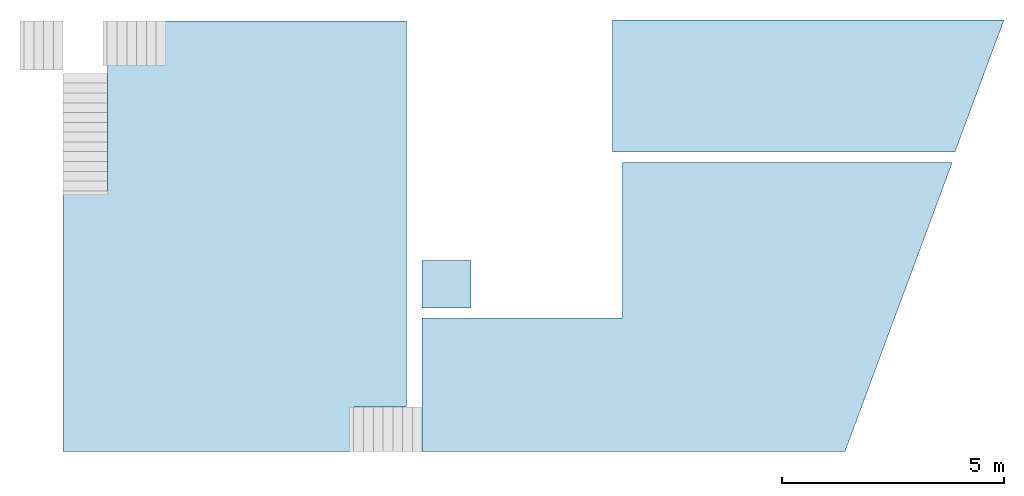
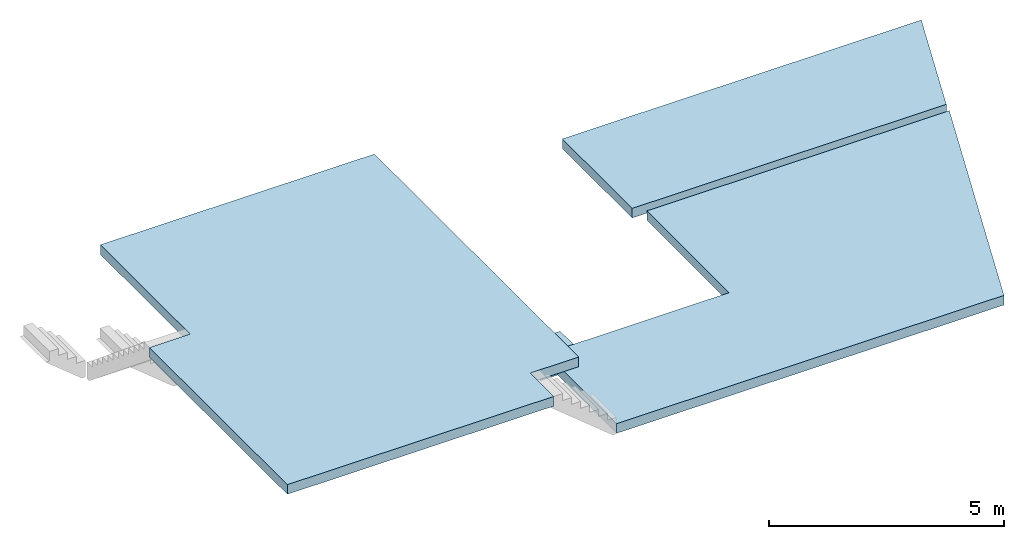
# One storey, part 1 of 2: 4 slabs.
"""IFC4 building model written with IfcOpenShell, lengths in metres."""

from ifc_helpers import new_model, entity, si_unit, converted_unit, frame, origin_with_axes, origin_2d_with_axis, place, context, subcontext, project, spatial, line, indexed_curve, outline, extrude, material, layer, layer_set, layer_usage, type_object, element, save


model = new_model("IFC4")

# Units and contexts
model_context = context("Model", 3, precision=1e-05, world=origin_with_axes())
plan_context = context("Plan", 2, precision=1e-05, world=origin_2d_with_axis())
body_context = subcontext(model_context, "Body", "Model", "MODEL_VIEW")
ifc_project = project(units=[si_unit("VOLUMEUNIT", "CUBIC_METRE"), si_unit("LENGTHUNIT", "METRE"), converted_unit("PLANEANGLEUNIT", "degree", entity("IfcReal", 0.0174532925199433), si_unit("PLANEANGLEUNIT", "RADIAN"), dimensions=[0, 0, 0, 0, 0, 0, 0]), si_unit("AREAUNIT", "SQUARE_METRE")], contexts=[model_context, plan_context])

# Site, building, storey
site_placement = place(None, origin_with_axes())
site = spatial("IfcSite", under=ifc_project, at=site_placement)
building_placement = place(site_placement, origin_with_axes())
building = spatial("IfcBuilding", under=site, at=building_placement)
storey_placement = place(building_placement, frame((0.0, 0.0, 4.23999977111816), z_axis=(0.0, 0.0, 1.0), x_axis=(1.0, 0.0, 0.0)))
storey = spatial("IfcBuildingStorey", under=building, at=storey_placement, Name="First floor")

# Slabs
ifc_material = material(Name="Concrete")
ifc_layer = layer(ifc_material, 0.25, Name="Concrete slab")
ifc_layer_set = layer_set([ifc_layer], Name="solid slab 250")
ifc_layer_usage_1 = layer_usage(ifc_layer_set, "AXIS3", "POSITIVE", 0.0)
slab_type = type_object("IfcSlabType", Name="concrete slab", PredefinedType="FLOOR", material=ifc_layer_set)
slab_1_placement = place(storey_placement, frame((21.3532009124756, 5.47878217697144, -0.25), z_axis=(0.0, 0.0, 1.0), x_axis=(1.0, 0.0, 0.0)))
element("IfcSlab", 1, at=slab_1_placement, inside=storey, type_object=slab_type, material=ifc_layer_usage_1, Name="Slab", context=body_context, shape_type="SweptSolid", body=[
    extrude(outline(indexed_curve([(0.0, 0.0), (9.5367431640625e-07, 5.85999870300293), (1.00000143051147, 5.85999965667725), (1.00000190734863, 9.67499923706055), (7.72000503540039, 9.67499923706055), (7.72000312805176, 1.00000238418579), (6.53000164031982, 1.00000190734863), (6.53000068664551, 1.9073486328125e-06)], segments=[line(2, 1), line(1, 8), line(8, 7), line(7, 6), line(6, 5), line(5, 4), line(4, 3), line(3, 2)], self_intersect=False)), None, (0.0, 0.0, 1.0), 0.25),
])
ifc_layer_usage_2 = layer_usage(ifc_layer_set, "AXIS3", "POSITIVE", 0.0)
slab_2_placement = place(storey_placement, frame((29.4232025146484, 5.47878265380859, -1.49428129196167), z_axis=(0.0, 0.0, 1.0), x_axis=(1.0, 0.0, 0.0)))
element("IfcSlab", 2, at=slab_2_placement, inside=storey, type_object=slab_type, material=ifc_layer_usage_2, Name="Slab", context=body_context, shape_type="SweptSolid", body=[
    extrude(outline(indexed_curve([(0.0, 0.0), (9.5, 0.0), (11.9123725891113, 6.49999904632568), (0.0, 2.99999904632568), (4.50000190734863, 6.49999856948853), (4.49499988555908, 3.0049991607666)], segments=[line(1, 2), line(2, 3), line(3, 5), line(5, 6), line(6, 4), line(4, 1)], self_intersect=False)), None, (0.0, 0.0, 1.0), 0.25),
])
ifc_layer_usage_3 = layer_usage(ifc_layer_set, "AXIS3", "POSITIVE", 0.0)
slab_3_placement = place(storey_placement, frame((33.6932029724121, 12.2087802886963, -1.48999977111816), z_axis=(0.0, 0.0, 1.0), x_axis=(1.0, 0.0, 0.0)))
element("IfcSlab", 3, at=slab_3_placement, inside=storey, type_object=slab_type, material=ifc_layer_usage_3, Name="Slab", context=body_context, shape_type="SweptSolid", body=[
    extrude(outline(indexed_curve([(8.8033332824707, 2.97000503540039), (7.70106887817383, 0.0), (0.0, 0.0), (0.0, 2.97000217437744)], segments=[line(4, 1), line(1, 2), line(2, 3), line(3, 4)], self_intersect=False)), None, (0.0, 0.0, 1.0), 0.25),
])
ifc_layer_usage_4 = layer_usage(ifc_layer_set, "AXIS3", "POSITIVE", 0.0)
slab_4_placement = place(storey_placement, frame((29.4232025146484, 8.70878124237061, -2.08887362480164), z_axis=(0.0, 0.0, 1.0), x_axis=(1.0, 0.0, 0.0)))
element("IfcSlab", 4, at=slab_4_placement, inside=storey, type_object=slab_type, material=ifc_layer_usage_4, Name="Slab", context=body_context, shape_type="SweptSolid", body=[
    extrude(outline(indexed_curve([(0.0, 0.0), (1.10000038146973, 0.0), (1.10000038146973, 1.07000064849854), (0.0, 1.07000064849854)], segments=[line(3, 2), line(2, 1), line(1, 4), line(4, 3)], self_intersect=False)), None, (0.0, 0.0, 1.0), 0.25),
])

save(model, "model.ifc")
